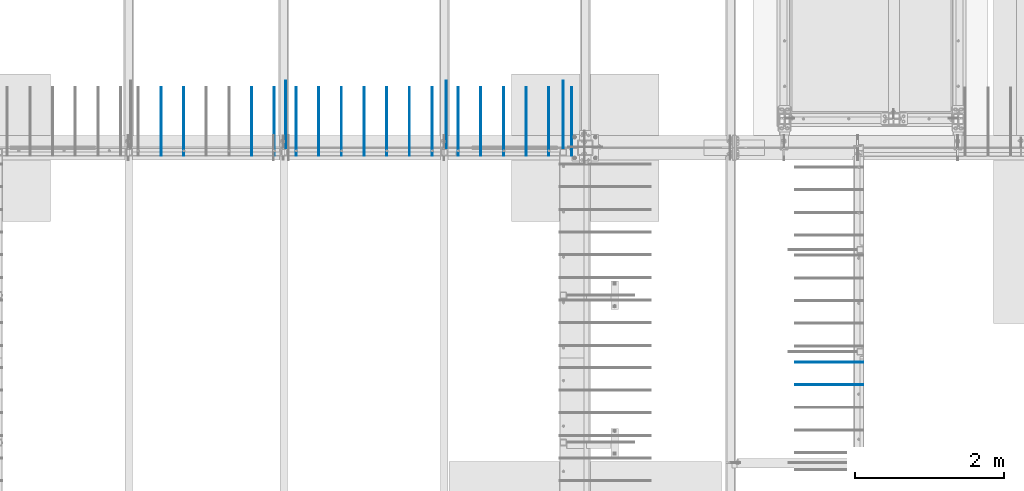
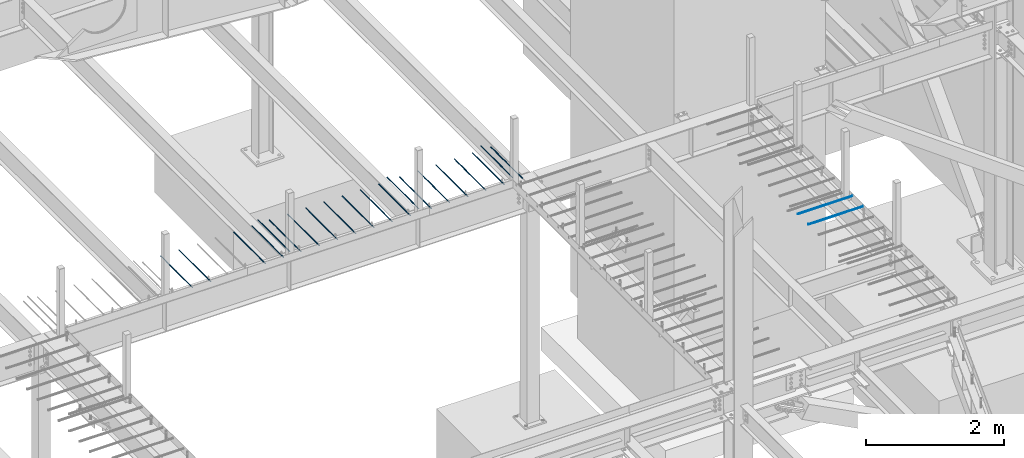
# One storey, part 821 of 1179: 22 beams, 22 elements without a shape of their own.
"""IFC2X3 building model written with IfcOpenShell, lengths in millimetres."""

from ifc_helpers import new_model, si_unit, frame, origin_with_axes, place, context, subcontext, project, spatial, faceted_brep, material, type_object, element, aggregate, save


model = new_model("IFC2X3")

# Units and contexts
model_context = context("Model", 3, precision=1e-05, world=origin_with_axes())
body_context = subcontext(model_context, "Body", "Model", "MODEL_VIEW")
ifc_project = project(units=[si_unit("LENGTHUNIT", "METRE", prefix="MILLI"), si_unit("AREAUNIT", "SQUARE_METRE"), si_unit("VOLUMEUNIT", "CUBIC_METRE"), si_unit("MASSUNIT", "GRAM", prefix="KILO"), si_unit("TIMEUNIT", "SECOND"), si_unit("PLANEANGLEUNIT", "RADIAN"), si_unit("SOLIDANGLEUNIT", "STERADIAN"), si_unit("THERMODYNAMICTEMPERATUREUNIT", "DEGREE_CELSIUS"), si_unit("LUMINOUSINTENSITYUNIT", "LUMEN")], contexts=[model_context])

# Site, building, storey
site_placement = place(None, origin_with_axes())
site = spatial("IfcSite", under=ifc_project, at=site_placement, CompositionType="ELEMENT")
building_placement = place(site_placement, origin_with_axes())
building = spatial("IfcBuilding", under=site, at=building_placement, Name="Undefined", CompositionType="ELEMENT")
storey_placement = place(building_placement, origin_with_axes())
storey = spatial("IfcBuildingStorey", under=building, at=storey_placement, Name="Undefined", CompositionType="ELEMENT", Elevation=0.0)

# Assembly, beam
assembly_1_placement = place(storey_placement, origin_with_axes())
assembly_1 = element("IfcElementAssembly", 1, at=assembly_1_placement, inside=storey, Name="#4 DOWEL", AssemblyPlace="NOTDEFINED", PredefinedType="NOTDEFINED")
ifc_material = material(Name="REBAR/A615-40")
beam_type = type_object("IfcBeamType", Name="#4 DOWEL", PredefinedType="NOTDEFINED")
beam_1_placement = place(assembly_1_placement, frame((14592.3, 11464.925, 4203.70000610352), z_axis=(0.0, 0.0, 1.0), x_axis=(0.0, 1.0, 0.0)))
beam_1 = element("IfcBeam", 2, at=beam_1_placement, type_object=beam_type, material=ifc_material, Name="#4 DOWEL", ObjectType="#4 DOWEL", context=body_context, shape_type="Brep", body=[
    faceted_brep([(0.0, -6.34999999999854, 0.0), (0.0, -4.49012806053361, -4.49012806053452), (914.399999999994, -4.49012806053452, -4.49012806042992), (914.399999999994, -6.34999999999991, 1.0550138540566e-10), (0.0, 0.0, -6.34999999999991), (914.399999999994, 0.0, -6.34999999989668), (0.0, 4.49012806053361, -4.49012806053452), (914.399999999994, 4.49012806053452, -4.49012806042992), (0.0, 6.34999999999854, 0.0), (914.399999999994, 6.34999999999991, 1.0550138540566e-10), (0.0, 4.49012806053361, 4.49012806053452), (914.399999999995, 4.49012806053452, 4.49012806064184), (0.0, 0.0, 6.34999999999991), (914.399999999995, 0.0, 6.35000000010768), (0.0, -4.49012806053361, 4.49012806053452), (914.399999999995, -4.49012806053452, 4.49012806064184)], [[[0, 1, 2, 3]], [[1, 4, 5, 2]], [[4, 6, 7, 5]], [[6, 8, 9, 7]], [[8, 10, 11, 9]], [[10, 12, 13, 11]], [[12, 14, 15, 13]], [[14, 0, 3, 15]], [[5, 7, 9, 11, 13, 15, 3, 2]], [[14, 12, 10, 8, 6, 4, 1, 0]]]),
])
aggregate(assembly_1, [beam_1])

assembly_2_placement = place(storey_placement, origin_with_axes())
assembly_2 = element("IfcElementAssembly", 3, at=assembly_2_placement, inside=storey, Name="#4 DOWEL", AssemblyPlace="NOTDEFINED", PredefinedType="NOTDEFINED")
beam_2_placement = place(assembly_2_placement, frame((12433.3, 11464.925, 4203.70000610352), z_axis=(0.0, 0.0, 1.0), x_axis=(0.0, 1.0, 0.0)))
beam_2 = element("IfcBeam", 4, at=beam_2_placement, type_object=beam_type, material=ifc_material, Name="#4 DOWEL", ObjectType="#4 DOWEL", context=body_context, shape_type="Brep", body=[
    faceted_brep([(0.0, -6.34999999999854, 0.0), (0.0, -4.49012806053361, -4.49012806053452), (914.399999999994, -4.49012806053452, -4.49012806042992), (914.399999999994, -6.34999999999991, 1.0550138540566e-10), (0.0, 0.0, -6.34999999999991), (914.399999999994, 0.0, -6.34999999989668), (0.0, 4.49012806053361, -4.49012806053452), (914.399999999994, 4.49012806053452, -4.49012806042992), (0.0, 6.34999999999854, 0.0), (914.399999999994, 6.34999999999991, 1.0550138540566e-10), (0.0, 4.49012806053361, 4.49012806053452), (914.399999999995, 4.49012806053452, 4.49012806064184), (0.0, 0.0, 6.34999999999991), (914.399999999995, 0.0, 6.35000000010768), (0.0, -4.49012806053361, 4.49012806053452), (914.399999999995, -4.49012806053452, 4.49012806064184)], [[[0, 1, 2, 3]], [[1, 4, 5, 2]], [[4, 6, 7, 5]], [[6, 8, 9, 7]], [[8, 10, 11, 9]], [[10, 12, 13, 11]], [[12, 14, 15, 13]], [[14, 0, 3, 15]], [[5, 7, 9, 11, 13, 15, 3, 2]], [[14, 12, 10, 8, 6, 4, 1, 0]]]),
])
aggregate(assembly_2, [beam_2])

assembly_3_placement = place(storey_placement, origin_with_axes())
assembly_3 = element("IfcElementAssembly", 5, at=assembly_3_placement, inside=storey, Name="#4 DOWEL", AssemblyPlace="NOTDEFINED", PredefinedType="NOTDEFINED")
beam_3_placement = place(assembly_3_placement, frame((19284.95, 8597.9, 4203.70000610352), z_axis=(0.0, 0.0, 1.0), x_axis=(1.0, 0.0, 0.0)))
beam_3 = element("IfcBeam", 6, at=beam_3_placement, type_object=beam_type, material=ifc_material, Name="#4 DOWEL", ObjectType="#4 DOWEL", context=body_context, shape_type="Brep", body=[
    faceted_brep([(0.0, -6.34999999999854, 0.0), (0.0, -4.49012806053361, -4.49012806053452), (914.399999999994, -4.49012806053452, -4.49012806042992), (914.399999999994, -6.34999999999991, 1.0550138540566e-10), (0.0, 0.0, -6.34999999999991), (914.399999999994, 0.0, -6.34999999989668), (0.0, 4.49012806053361, -4.49012806053452), (914.399999999994, 4.49012806053452, -4.49012806042992), (0.0, 6.34999999999854, 0.0), (914.399999999994, 6.34999999999991, 1.0550138540566e-10), (0.0, 4.49012806053361, 4.49012806053452), (914.399999999995, 4.49012806053452, 4.49012806064184), (0.0, 0.0, 6.34999999999991), (914.399999999995, 0.0, 6.35000000010768), (0.0, -4.49012806053361, 4.49012806053452), (914.399999999995, -4.49012806053452, 4.49012806064184)], [[[0, 1, 2, 3]], [[1, 4, 5, 2]], [[4, 6, 7, 5]], [[6, 8, 9, 7]], [[8, 10, 11, 9]], [[10, 12, 13, 11]], [[12, 14, 15, 13]], [[14, 0, 3, 15]], [[5, 7, 9, 11, 13, 15, 3, 2]], [[14, 12, 10, 8, 6, 4, 1, 0]]]),
])
aggregate(assembly_3, [beam_3])

assembly_4_placement = place(storey_placement, origin_with_axes())
assembly_4 = element("IfcElementAssembly", 7, at=assembly_4_placement, inside=storey, Name="#4 DOWEL", AssemblyPlace="NOTDEFINED", PredefinedType="NOTDEFINED")
beam_4_placement = place(assembly_4_placement, frame((19284.95, 8293.1, 4203.70000610352), z_axis=(0.0, 0.0, 1.0), x_axis=(1.0, 0.0, 0.0)))
beam_4 = element("IfcBeam", 8, at=beam_4_placement, type_object=beam_type, material=ifc_material, Name="#4 DOWEL", ObjectType="#4 DOWEL", context=body_context, shape_type="Brep", body=[
    faceted_brep([(0.0, -6.34999999999854, 0.0), (0.0, -4.49012806053361, -4.49012806053452), (914.399999999994, -4.49012806053452, -4.49012806042992), (914.399999999994, -6.34999999999991, 1.0550138540566e-10), (0.0, 0.0, -6.34999999999991), (914.399999999994, 0.0, -6.34999999989668), (0.0, 4.49012806053361, -4.49012806053452), (914.399999999994, 4.49012806053452, -4.49012806042992), (0.0, 6.34999999999854, 0.0), (914.399999999994, 6.34999999999991, 1.0550138540566e-10), (0.0, 4.49012806053361, 4.49012806053452), (914.399999999995, 4.49012806053452, 4.49012806064184), (0.0, 0.0, 6.34999999999991), (914.399999999995, 0.0, 6.35000000010768), (0.0, -4.49012806053361, 4.49012806053452), (914.399999999995, -4.49012806053452, 4.49012806064184)], [[[0, 1, 2, 3]], [[1, 4, 5, 2]], [[4, 6, 7, 5]], [[6, 8, 9, 7]], [[8, 10, 11, 9]], [[10, 12, 13, 11]], [[12, 14, 15, 13]], [[14, 0, 3, 15]], [[5, 7, 9, 11, 13, 15, 3, 2]], [[14, 12, 10, 8, 6, 4, 1, 0]]]),
])
aggregate(assembly_4, [beam_4])

assembly_5_placement = place(storey_placement, origin_with_axes())
assembly_5 = element("IfcElementAssembly", 9, at=assembly_5_placement, inside=storey, Name="#4 DOWEL", AssemblyPlace="NOTDEFINED", PredefinedType="NOTDEFINED")
beam_5_placement = place(assembly_5_placement, frame((16163.925, 11464.925, 4203.70000610352), z_axis=(0.0, 0.0, 1.0), x_axis=(0.0, 1.0, 0.0)))
beam_5 = element("IfcBeam", 10, at=beam_5_placement, type_object=beam_type, material=ifc_material, Name="#4 DOWEL", ObjectType="#4 DOWEL", context=body_context, shape_type="Brep", body=[
    faceted_brep([(0.0, -6.34999999999854, 0.0), (0.0, -4.49012806053361, -4.49012806053452), (914.399999999994, -4.49012806053452, -4.49012806042992), (914.399999999994, -6.34999999999991, 1.0550138540566e-10), (0.0, 0.0, -6.34999999999991), (914.399999999994, 0.0, -6.34999999989668), (0.0, 4.49012806053361, -4.49012806053452), (914.399999999994, 4.49012806053452, -4.49012806042992), (0.0, 6.34999999999854, 0.0), (914.399999999994, 6.34999999999991, 1.0550138540566e-10), (0.0, 4.49012806053361, 4.49012806053452), (914.399999999995, 4.49012806053452, 4.49012806064184), (0.0, 0.0, 6.34999999999991), (914.399999999995, 0.0, 6.35000000010768), (0.0, -4.49012806053361, 4.49012806053452), (914.399999999995, -4.49012806053452, 4.49012806064184)], [[[0, 1, 2, 3]], [[1, 4, 5, 2]], [[4, 6, 7, 5]], [[6, 8, 9, 7]], [[8, 10, 11, 9]], [[10, 12, 13, 11]], [[12, 14, 15, 13]], [[14, 0, 3, 15]], [[5, 7, 9, 11, 13, 15, 3, 2]], [[14, 12, 10, 8, 6, 4, 1, 0]]]),
])
aggregate(assembly_5, [beam_5])

assembly_6_placement = place(storey_placement, origin_with_axes())
assembly_6 = element("IfcElementAssembly", 11, at=assembly_6_placement, inside=storey, Name="#4 DOWEL", AssemblyPlace="NOTDEFINED", PredefinedType="NOTDEFINED")
beam_6_placement = place(assembly_6_placement, frame((16276.6375, 11376.025, 4203.70000610352), z_axis=(0.0, 0.0, 1.0), x_axis=(0.0, 1.0, 0.0)))
beam_6 = element("IfcBeam", 12, at=beam_6_placement, type_object=beam_type, material=ifc_material, Name="#4 DOWEL", ObjectType="#4 DOWEL", context=body_context, shape_type="Brep", body=[
    faceted_brep([(0.0, -6.34999999999854, 0.0), (0.0, -4.49012806053361, -4.49012806053452), (914.399999999994, -4.49012806053452, -4.49012806042992), (914.399999999994, -6.34999999999991, 1.0550138540566e-10), (0.0, 0.0, -6.34999999999991), (914.399999999994, 0.0, -6.34999999989668), (0.0, 4.49012806053361, -4.49012806053452), (914.399999999994, 4.49012806053452, -4.49012806042992), (0.0, 6.34999999999854, 0.0), (914.399999999994, 6.34999999999991, 1.0550138540566e-10), (0.0, 4.49012806053361, 4.49012806053452), (914.399999999995, 4.49012806053452, 4.49012806064184), (0.0, 0.0, 6.34999999999991), (914.399999999995, 0.0, 6.35000000010768), (0.0, -4.49012806053361, 4.49012806053452), (914.399999999995, -4.49012806053452, 4.49012806064184)], [[[0, 1, 2, 3]], [[1, 4, 5, 2]], [[4, 6, 7, 5]], [[6, 8, 9, 7]], [[8, 10, 11, 9]], [[10, 12, 13, 11]], [[12, 14, 15, 13]], [[14, 0, 3, 15]], [[5, 7, 9, 11, 13, 15, 3, 2]], [[14, 12, 10, 8, 6, 4, 1, 0]]]),
])
aggregate(assembly_6, [beam_6])

assembly_7_placement = place(storey_placement, origin_with_axes())
assembly_7 = element("IfcElementAssembly", 13, at=assembly_7_placement, inside=storey, Name="#4 DOWEL", AssemblyPlace="NOTDEFINED", PredefinedType="NOTDEFINED")
beam_7_placement = place(assembly_7_placement, frame((15971.8375, 11376.025, 4203.70000610352), z_axis=(0.0, 0.0, 1.0), x_axis=(0.0, 1.0, 0.0)))
beam_7 = element("IfcBeam", 14, at=beam_7_placement, type_object=beam_type, material=ifc_material, Name="#4 DOWEL", ObjectType="#4 DOWEL", context=body_context, shape_type="Brep", body=[
    faceted_brep([(0.0, -6.34999999999854, 0.0), (0.0, -4.49012806053361, -4.49012806053452), (914.399999999994, -4.49012806053452, -4.49012806042992), (914.399999999994, -6.34999999999991, 1.0550138540566e-10), (0.0, 0.0, -6.34999999999991), (914.399999999994, 0.0, -6.34999999989668), (0.0, 4.49012806053361, -4.49012806053452), (914.399999999994, 4.49012806053452, -4.49012806042992), (0.0, 6.34999999999854, 0.0), (914.399999999994, 6.34999999999991, 1.0550138540566e-10), (0.0, 4.49012806053361, 4.49012806053452), (914.399999999995, 4.49012806053452, 4.49012806064184), (0.0, 0.0, 6.34999999999991), (914.399999999995, 0.0, 6.35000000010768), (0.0, -4.49012806053361, 4.49012806053452), (914.399999999995, -4.49012806053452, 4.49012806064184)], [[[0, 1, 2, 3]], [[1, 4, 5, 2]], [[4, 6, 7, 5]], [[6, 8, 9, 7]], [[8, 10, 11, 9]], [[10, 12, 13, 11]], [[12, 14, 15, 13]], [[14, 0, 3, 15]], [[5, 7, 9, 11, 13, 15, 3, 2]], [[14, 12, 10, 8, 6, 4, 1, 0]]]),
])
aggregate(assembly_7, [beam_7])

assembly_8_placement = place(storey_placement, origin_with_axes())
assembly_8 = element("IfcElementAssembly", 15, at=assembly_8_placement, inside=storey, Name="#4 DOWEL", AssemblyPlace="NOTDEFINED", PredefinedType="NOTDEFINED")
beam_8_placement = place(assembly_8_placement, frame((15667.0375, 11376.025, 4203.70000610352), z_axis=(0.0, 0.0, 1.0), x_axis=(0.0, 1.0, 0.0)))
beam_8 = element("IfcBeam", 16, at=beam_8_placement, type_object=beam_type, material=ifc_material, Name="#4 DOWEL", ObjectType="#4 DOWEL", context=body_context, shape_type="Brep", body=[
    faceted_brep([(0.0, -6.34999999999854, 0.0), (0.0, -4.49012806053361, -4.49012806053452), (914.399999999994, -4.49012806053452, -4.49012806042992), (914.399999999994, -6.34999999999991, 1.0550138540566e-10), (0.0, 0.0, -6.34999999999991), (914.399999999994, 0.0, -6.34999999989668), (0.0, 4.49012806053361, -4.49012806053452), (914.399999999994, 4.49012806053452, -4.49012806042992), (0.0, 6.34999999999854, 0.0), (914.399999999994, 6.34999999999991, 1.0550138540566e-10), (0.0, 4.49012806053361, 4.49012806053452), (914.399999999995, 4.49012806053452, 4.49012806064184), (0.0, 0.0, 6.34999999999991), (914.399999999995, 0.0, 6.35000000010768), (0.0, -4.49012806053361, 4.49012806053452), (914.399999999995, -4.49012806053452, 4.49012806064184)], [[[0, 1, 2, 3]], [[1, 4, 5, 2]], [[4, 6, 7, 5]], [[6, 8, 9, 7]], [[8, 10, 11, 9]], [[10, 12, 13, 11]], [[12, 14, 15, 13]], [[14, 0, 3, 15]], [[5, 7, 9, 11, 13, 15, 3, 2]], [[14, 12, 10, 8, 6, 4, 1, 0]]]),
])
aggregate(assembly_8, [beam_8])

assembly_9_placement = place(storey_placement, origin_with_axes())
assembly_9 = element("IfcElementAssembly", 17, at=assembly_9_placement, inside=storey, Name="#4 DOWEL", AssemblyPlace="NOTDEFINED", PredefinedType="NOTDEFINED")
beam_9_placement = place(assembly_9_placement, frame((15362.2375, 11376.025, 4203.70000610352), z_axis=(0.0, 0.0, 1.0), x_axis=(0.0, 1.0, 0.0)))
beam_9 = element("IfcBeam", 18, at=beam_9_placement, type_object=beam_type, material=ifc_material, Name="#4 DOWEL", ObjectType="#4 DOWEL", context=body_context, shape_type="Brep", body=[
    faceted_brep([(0.0, -6.34999999999854, 0.0), (0.0, -4.49012806053361, -4.49012806053452), (914.399999999994, -4.49012806053452, -4.49012806042992), (914.399999999994, -6.34999999999991, 1.0550138540566e-10), (0.0, 0.0, -6.34999999999991), (914.399999999994, 0.0, -6.34999999989668), (0.0, 4.49012806053361, -4.49012806053452), (914.399999999994, 4.49012806053452, -4.49012806042992), (0.0, 6.34999999999854, 0.0), (914.399999999994, 6.34999999999991, 1.0550138540566e-10), (0.0, 4.49012806053361, 4.49012806053452), (914.399999999995, 4.49012806053452, 4.49012806064184), (0.0, 0.0, 6.34999999999991), (914.399999999995, 0.0, 6.35000000010768), (0.0, -4.49012806053361, 4.49012806053452), (914.399999999995, -4.49012806053452, 4.49012806064184)], [[[0, 1, 2, 3]], [[1, 4, 5, 2]], [[4, 6, 7, 5]], [[6, 8, 9, 7]], [[8, 10, 11, 9]], [[10, 12, 13, 11]], [[12, 14, 15, 13]], [[14, 0, 3, 15]], [[5, 7, 9, 11, 13, 15, 3, 2]], [[14, 12, 10, 8, 6, 4, 1, 0]]]),
])
aggregate(assembly_9, [beam_9])

assembly_10_placement = place(storey_placement, origin_with_axes())
assembly_10 = element("IfcElementAssembly", 19, at=assembly_10_placement, inside=storey, Name="#4 DOWEL", AssemblyPlace="NOTDEFINED", PredefinedType="NOTDEFINED")
beam_10_placement = place(assembly_10_placement, frame((15057.4375, 11376.025, 4203.70000610352), z_axis=(0.0, 0.0, 1.0), x_axis=(0.0, 1.0, 0.0)))
beam_10 = element("IfcBeam", 20, at=beam_10_placement, type_object=beam_type, material=ifc_material, Name="#4 DOWEL", ObjectType="#4 DOWEL", context=body_context, shape_type="Brep", body=[
    faceted_brep([(0.0, -6.34999999999854, 0.0), (0.0, -4.49012806053361, -4.49012806053452), (914.399999999994, -4.49012806053452, -4.49012806042992), (914.399999999994, -6.34999999999991, 1.0550138540566e-10), (0.0, 0.0, -6.34999999999991), (914.399999999994, 0.0, -6.34999999989668), (0.0, 4.49012806053361, -4.49012806053452), (914.399999999994, 4.49012806053452, -4.49012806042992), (0.0, 6.34999999999854, 0.0), (914.399999999994, 6.34999999999991, 1.0550138540566e-10), (0.0, 4.49012806053361, 4.49012806053452), (914.399999999995, 4.49012806053452, 4.49012806064184), (0.0, 0.0, 6.34999999999991), (914.399999999995, 0.0, 6.35000000010768), (0.0, -4.49012806053361, 4.49012806053452), (914.399999999995, -4.49012806053452, 4.49012806064184)], [[[0, 1, 2, 3]], [[1, 4, 5, 2]], [[4, 6, 7, 5]], [[6, 8, 9, 7]], [[8, 10, 11, 9]], [[10, 12, 13, 11]], [[12, 14, 15, 13]], [[14, 0, 3, 15]], [[5, 7, 9, 11, 13, 15, 3, 2]], [[14, 12, 10, 8, 6, 4, 1, 0]]]),
])
aggregate(assembly_10, [beam_10])

assembly_11_placement = place(storey_placement, origin_with_axes())
assembly_11 = element("IfcElementAssembly", 21, at=assembly_11_placement, inside=storey, Name="#4 DOWEL", AssemblyPlace="NOTDEFINED", PredefinedType="NOTDEFINED")
beam_11_placement = place(assembly_11_placement, frame((14752.6375, 11376.025, 4203.70000610352), z_axis=(0.0, 0.0, 1.0), x_axis=(0.0, 1.0, 0.0)))
beam_11 = element("IfcBeam", 22, at=beam_11_placement, type_object=beam_type, material=ifc_material, Name="#4 DOWEL", ObjectType="#4 DOWEL", context=body_context, shape_type="Brep", body=[
    faceted_brep([(0.0, -6.34999999999854, 0.0), (0.0, -4.49012806053361, -4.49012806053452), (914.399999999994, -4.49012806053452, -4.49012806042992), (914.399999999994, -6.34999999999991, 1.0550138540566e-10), (0.0, 0.0, -6.34999999999991), (914.399999999994, 0.0, -6.34999999989668), (0.0, 4.49012806053361, -4.49012806053452), (914.399999999994, 4.49012806053452, -4.49012806042992), (0.0, 6.34999999999854, 0.0), (914.399999999994, 6.34999999999991, 1.0550138540566e-10), (0.0, 4.49012806053361, 4.49012806053452), (914.399999999995, 4.49012806053452, 4.49012806064184), (0.0, 0.0, 6.34999999999991), (914.399999999995, 0.0, 6.35000000010768), (0.0, -4.49012806053361, 4.49012806053452), (914.399999999995, -4.49012806053452, 4.49012806064184)], [[[0, 1, 2, 3]], [[1, 4, 5, 2]], [[4, 6, 7, 5]], [[6, 8, 9, 7]], [[8, 10, 11, 9]], [[10, 12, 13, 11]], [[12, 14, 15, 13]], [[14, 0, 3, 15]], [[5, 7, 9, 11, 13, 15, 3, 2]], [[14, 12, 10, 8, 6, 4, 1, 0]]]),
])
aggregate(assembly_11, [beam_11])

assembly_12_placement = place(storey_placement, origin_with_axes())
assembly_12 = element("IfcElementAssembly", 23, at=assembly_12_placement, inside=storey, Name="#4 DOWEL", AssemblyPlace="NOTDEFINED", PredefinedType="NOTDEFINED")
beam_12_placement = place(assembly_12_placement, frame((14401.8, 11376.025, 4203.70000610352), z_axis=(0.0, 0.0, 1.0), x_axis=(0.0, 1.0, 0.0)))
beam_12 = element("IfcBeam", 24, at=beam_12_placement, type_object=beam_type, material=ifc_material, Name="#4 DOWEL", ObjectType="#4 DOWEL", context=body_context, shape_type="Brep", body=[
    faceted_brep([(0.0, -6.34999999999854, 0.0), (0.0, -4.49012806053361, -4.49012806053452), (914.399999999994, -4.49012806053452, -4.49012806042992), (914.399999999994, -6.34999999999991, 1.0550138540566e-10), (0.0, 0.0, -6.34999999999991), (914.399999999994, 0.0, -6.34999999989668), (0.0, 4.49012806053361, -4.49012806053452), (914.399999999994, 4.49012806053452, -4.49012806042992), (0.0, 6.34999999999854, 0.0), (914.399999999994, 6.34999999999991, 1.0550138540566e-10), (0.0, 4.49012806053361, 4.49012806053452), (914.399999999995, 4.49012806053452, 4.49012806064184), (0.0, 0.0, 6.34999999999991), (914.399999999995, 0.0, 6.35000000010768), (0.0, -4.49012806053361, 4.49012806053452), (914.399999999995, -4.49012806053452, 4.49012806064184)], [[[0, 1, 2, 3]], [[1, 4, 5, 2]], [[4, 6, 7, 5]], [[6, 8, 9, 7]], [[8, 10, 11, 9]], [[10, 12, 13, 11]], [[12, 14, 15, 13]], [[14, 0, 3, 15]], [[5, 7, 9, 11, 13, 15, 3, 2]], [[14, 12, 10, 8, 6, 4, 1, 0]]]),
])
aggregate(assembly_12, [beam_12])

assembly_13_placement = place(storey_placement, origin_with_axes())
assembly_13 = element("IfcElementAssembly", 25, at=assembly_13_placement, inside=storey, Name="#4 DOWEL", AssemblyPlace="NOTDEFINED", PredefinedType="NOTDEFINED")
beam_13_placement = place(assembly_13_placement, frame((14097.0, 11376.025, 4203.70000610352), z_axis=(0.0, 0.0, 1.0), x_axis=(0.0, 1.0, 0.0)))
beam_13 = element("IfcBeam", 26, at=beam_13_placement, type_object=beam_type, material=ifc_material, Name="#4 DOWEL", ObjectType="#4 DOWEL", context=body_context, shape_type="Brep", body=[
    faceted_brep([(0.0, -6.34999999999854, 0.0), (0.0, -4.49012806053361, -4.49012806053452), (914.399999999994, -4.49012806053452, -4.49012806042992), (914.399999999994, -6.34999999999991, 1.0550138540566e-10), (0.0, 0.0, -6.34999999999991), (914.399999999994, 0.0, -6.34999999989668), (0.0, 4.49012806053361, -4.49012806053452), (914.399999999994, 4.49012806053452, -4.49012806042992), (0.0, 6.34999999999854, 0.0), (914.399999999994, 6.34999999999991, 1.0550138540566e-10), (0.0, 4.49012806053361, 4.49012806053452), (914.399999999995, 4.49012806053452, 4.49012806064184), (0.0, 0.0, 6.34999999999991), (914.399999999995, 0.0, 6.35000000010768), (0.0, -4.49012806053361, 4.49012806053452), (914.399999999995, -4.49012806053452, 4.49012806064184)], [[[0, 1, 2, 3]], [[1, 4, 5, 2]], [[4, 6, 7, 5]], [[6, 8, 9, 7]], [[8, 10, 11, 9]], [[10, 12, 13, 11]], [[12, 14, 15, 13]], [[14, 0, 3, 15]], [[5, 7, 9, 11, 13, 15, 3, 2]], [[14, 12, 10, 8, 6, 4, 1, 0]]]),
])
aggregate(assembly_13, [beam_13])

assembly_14_placement = place(storey_placement, origin_with_axes())
assembly_14 = element("IfcElementAssembly", 27, at=assembly_14_placement, inside=storey, Name="#4 DOWEL", AssemblyPlace="NOTDEFINED", PredefinedType="NOTDEFINED")
beam_14_placement = place(assembly_14_placement, frame((13792.2, 11376.025, 4203.70000610352), z_axis=(0.0, 0.0, 1.0), x_axis=(0.0, 1.0, 0.0)))
beam_14 = element("IfcBeam", 28, at=beam_14_placement, type_object=beam_type, material=ifc_material, Name="#4 DOWEL", ObjectType="#4 DOWEL", context=body_context, shape_type="Brep", body=[
    faceted_brep([(0.0, -6.34999999999854, 0.0), (0.0, -4.49012806053361, -4.49012806053452), (914.399999999994, -4.49012806053452, -4.49012806042992), (914.399999999994, -6.34999999999991, 1.0550138540566e-10), (0.0, 0.0, -6.34999999999991), (914.399999999994, 0.0, -6.34999999989668), (0.0, 4.49012806053361, -4.49012806053452), (914.399999999994, 4.49012806053452, -4.49012806042992), (0.0, 6.34999999999854, 0.0), (914.399999999994, 6.34999999999991, 1.0550138540566e-10), (0.0, 4.49012806053361, 4.49012806053452), (914.399999999995, 4.49012806053452, 4.49012806064184), (0.0, 0.0, 6.34999999999991), (914.399999999995, 0.0, 6.35000000010768), (0.0, -4.49012806053361, 4.49012806053452), (914.399999999995, -4.49012806053452, 4.49012806064184)], [[[0, 1, 2, 3]], [[1, 4, 5, 2]], [[4, 6, 7, 5]], [[6, 8, 9, 7]], [[8, 10, 11, 9]], [[10, 12, 13, 11]], [[12, 14, 15, 13]], [[14, 0, 3, 15]], [[5, 7, 9, 11, 13, 15, 3, 2]], [[14, 12, 10, 8, 6, 4, 1, 0]]]),
])
aggregate(assembly_14, [beam_14])

assembly_15_placement = place(storey_placement, origin_with_axes())
assembly_15 = element("IfcElementAssembly", 29, at=assembly_15_placement, inside=storey, Name="#4 DOWEL", AssemblyPlace="NOTDEFINED", PredefinedType="NOTDEFINED")
beam_15_placement = place(assembly_15_placement, frame((13487.4, 11376.025, 4203.70000610352), z_axis=(0.0, 0.0, 1.0), x_axis=(0.0, 1.0, 0.0)))
beam_15 = element("IfcBeam", 30, at=beam_15_placement, type_object=beam_type, material=ifc_material, Name="#4 DOWEL", ObjectType="#4 DOWEL", context=body_context, shape_type="Brep", body=[
    faceted_brep([(0.0, -6.34999999999854, 0.0), (0.0, -4.49012806053361, -4.49012806053452), (914.399999999994, -4.49012806053452, -4.49012806042992), (914.399999999994, -6.34999999999991, 1.0550138540566e-10), (0.0, 0.0, -6.34999999999991), (914.399999999994, 0.0, -6.34999999989668), (0.0, 4.49012806053361, -4.49012806053452), (914.399999999994, 4.49012806053452, -4.49012806042992), (0.0, 6.34999999999854, 0.0), (914.399999999994, 6.34999999999991, 1.0550138540566e-10), (0.0, 4.49012806053361, 4.49012806053452), (914.399999999995, 4.49012806053452, 4.49012806064184), (0.0, 0.0, 6.34999999999991), (914.399999999995, 0.0, 6.35000000010768), (0.0, -4.49012806053361, 4.49012806053452), (914.399999999995, -4.49012806053452, 4.49012806064184)], [[[0, 1, 2, 3]], [[1, 4, 5, 2]], [[4, 6, 7, 5]], [[6, 8, 9, 7]], [[8, 10, 11, 9]], [[10, 12, 13, 11]], [[12, 14, 15, 13]], [[14, 0, 3, 15]], [[5, 7, 9, 11, 13, 15, 3, 2]], [[14, 12, 10, 8, 6, 4, 1, 0]]]),
])
aggregate(assembly_15, [beam_15])

assembly_16_placement = place(storey_placement, origin_with_axes())
assembly_16 = element("IfcElementAssembly", 31, at=assembly_16_placement, inside=storey, Name="#4 DOWEL", AssemblyPlace="NOTDEFINED", PredefinedType="NOTDEFINED")
beam_16_placement = place(assembly_16_placement, frame((13182.6, 11376.025, 4203.70000610352), z_axis=(0.0, 0.0, 1.0), x_axis=(0.0, 1.0, 0.0)))
beam_16 = element("IfcBeam", 32, at=beam_16_placement, type_object=beam_type, material=ifc_material, Name="#4 DOWEL", ObjectType="#4 DOWEL", context=body_context, shape_type="Brep", body=[
    faceted_brep([(0.0, -6.34999999999854, 0.0), (0.0, -4.49012806053361, -4.49012806053452), (914.399999999994, -4.49012806053452, -4.49012806042992), (914.399999999994, -6.34999999999991, 1.0550138540566e-10), (0.0, 0.0, -6.34999999999991), (914.399999999994, 0.0, -6.34999999989668), (0.0, 4.49012806053361, -4.49012806053452), (914.399999999994, 4.49012806053452, -4.49012806042992), (0.0, 6.34999999999854, 0.0), (914.399999999994, 6.34999999999991, 1.0550138540566e-10), (0.0, 4.49012806053361, 4.49012806053452), (914.399999999995, 4.49012806053452, 4.49012806064184), (0.0, 0.0, 6.34999999999991), (914.399999999995, 0.0, 6.35000000010768), (0.0, -4.49012806053361, 4.49012806053452), (914.399999999995, -4.49012806053452, 4.49012806064184)], [[[0, 1, 2, 3]], [[1, 4, 5, 2]], [[4, 6, 7, 5]], [[6, 8, 9, 7]], [[8, 10, 11, 9]], [[10, 12, 13, 11]], [[12, 14, 15, 13]], [[14, 0, 3, 15]], [[5, 7, 9, 11, 13, 15, 3, 2]], [[14, 12, 10, 8, 6, 4, 1, 0]]]),
])
aggregate(assembly_16, [beam_16])

assembly_17_placement = place(storey_placement, origin_with_axes())
assembly_17 = element("IfcElementAssembly", 33, at=assembly_17_placement, inside=storey, Name="#4 DOWEL", AssemblyPlace="NOTDEFINED", PredefinedType="NOTDEFINED")
beam_17_placement = place(assembly_17_placement, frame((12877.8, 11376.025, 4203.70000610352), z_axis=(0.0, 0.0, 1.0), x_axis=(0.0, 1.0, 0.0)))
beam_17 = element("IfcBeam", 34, at=beam_17_placement, type_object=beam_type, material=ifc_material, Name="#4 DOWEL", ObjectType="#4 DOWEL", context=body_context, shape_type="Brep", body=[
    faceted_brep([(0.0, -6.34999999999854, 0.0), (0.0, -4.49012806053361, -4.49012806053452), (914.399999999994, -4.49012806053452, -4.49012806042992), (914.399999999994, -6.34999999999991, 1.0550138540566e-10), (0.0, 0.0, -6.34999999999991), (914.399999999994, 0.0, -6.34999999989668), (0.0, 4.49012806053361, -4.49012806053452), (914.399999999994, 4.49012806053452, -4.49012806042992), (0.0, 6.34999999999854, 0.0), (914.399999999994, 6.34999999999991, 1.0550138540566e-10), (0.0, 4.49012806053361, 4.49012806053452), (914.399999999995, 4.49012806053452, 4.49012806064184), (0.0, 0.0, 6.34999999999991), (914.399999999995, 0.0, 6.35000000010768), (0.0, -4.49012806053361, 4.49012806053452), (914.399999999995, -4.49012806053452, 4.49012806064184)], [[[0, 1, 2, 3]], [[1, 4, 5, 2]], [[4, 6, 7, 5]], [[6, 8, 9, 7]], [[8, 10, 11, 9]], [[10, 12, 13, 11]], [[12, 14, 15, 13]], [[14, 0, 3, 15]], [[5, 7, 9, 11, 13, 15, 3, 2]], [[14, 12, 10, 8, 6, 4, 1, 0]]]),
])
aggregate(assembly_17, [beam_17])

assembly_18_placement = place(storey_placement, origin_with_axes())
assembly_18 = element("IfcElementAssembly", 35, at=assembly_18_placement, inside=storey, Name="#4 DOWEL", AssemblyPlace="NOTDEFINED", PredefinedType="NOTDEFINED")
beam_18_placement = place(assembly_18_placement, frame((12573.0, 11376.025, 4203.70000610352), z_axis=(0.0, 0.0, 1.0), x_axis=(0.0, 1.0, 0.0)))
beam_18 = element("IfcBeam", 36, at=beam_18_placement, type_object=beam_type, material=ifc_material, Name="#4 DOWEL", ObjectType="#4 DOWEL", context=body_context, shape_type="Brep", body=[
    faceted_brep([(0.0, -6.34999999999854, 0.0), (0.0, -4.49012806053361, -4.49012806053452), (914.399999999994, -4.49012806053452, -4.49012806042992), (914.399999999994, -6.34999999999991, 1.0550138540566e-10), (0.0, 0.0, -6.34999999999991), (914.399999999994, 0.0, -6.34999999989668), (0.0, 4.49012806053361, -4.49012806053452), (914.399999999994, 4.49012806053452, -4.49012806042992), (0.0, 6.34999999999854, 0.0), (914.399999999994, 6.34999999999991, 1.0550138540566e-10), (0.0, 4.49012806053361, 4.49012806053452), (914.399999999995, 4.49012806053452, 4.49012806064184), (0.0, 0.0, 6.34999999999991), (914.399999999995, 0.0, 6.35000000010768), (0.0, -4.49012806053361, 4.49012806053452), (914.399999999995, -4.49012806053452, 4.49012806064184)], [[[0, 1, 2, 3]], [[1, 4, 5, 2]], [[4, 6, 7, 5]], [[6, 8, 9, 7]], [[8, 10, 11, 9]], [[10, 12, 13, 11]], [[12, 14, 15, 13]], [[14, 0, 3, 15]], [[5, 7, 9, 11, 13, 15, 3, 2]], [[14, 12, 10, 8, 6, 4, 1, 0]]]),
])
aggregate(assembly_18, [beam_18])

assembly_19_placement = place(storey_placement, origin_with_axes())
assembly_19 = element("IfcElementAssembly", 37, at=assembly_19_placement, inside=storey, Name="#4 DOWEL", AssemblyPlace="NOTDEFINED", PredefinedType="NOTDEFINED")
beam_19_placement = place(assembly_19_placement, frame((12280.9, 11376.025, 4203.70000610352), z_axis=(0.0, 0.0, 1.0), x_axis=(0.0, 1.0, 0.0)))
beam_19 = element("IfcBeam", 38, at=beam_19_placement, type_object=beam_type, material=ifc_material, Name="#4 DOWEL", ObjectType="#4 DOWEL", context=body_context, shape_type="Brep", body=[
    faceted_brep([(0.0, -6.34999999999854, 0.0), (0.0, -4.49012806053361, -4.49012806053452), (914.399999999994, -4.49012806053452, -4.49012806042992), (914.399999999994, -6.34999999999991, 1.0550138540566e-10), (0.0, 0.0, -6.34999999999991), (914.399999999994, 0.0, -6.34999999989668), (0.0, 4.49012806053361, -4.49012806053452), (914.399999999994, 4.49012806053452, -4.49012806042992), (0.0, 6.34999999999854, 0.0), (914.399999999994, 6.34999999999991, 1.0550138540566e-10), (0.0, 4.49012806053361, 4.49012806053452), (914.399999999995, 4.49012806053452, 4.49012806064184), (0.0, 0.0, 6.34999999999991), (914.399999999995, 0.0, 6.35000000010768), (0.0, -4.49012806053361, 4.49012806053452), (914.399999999995, -4.49012806053452, 4.49012806064184)], [[[0, 1, 2, 3]], [[1, 4, 5, 2]], [[4, 6, 7, 5]], [[6, 8, 9, 7]], [[8, 10, 11, 9]], [[10, 12, 13, 11]], [[12, 14, 15, 13]], [[14, 0, 3, 15]], [[5, 7, 9, 11, 13, 15, 3, 2]], [[14, 12, 10, 8, 6, 4, 1, 0]]]),
])
aggregate(assembly_19, [beam_19])

assembly_20_placement = place(storey_placement, origin_with_axes())
assembly_20 = element("IfcElementAssembly", 39, at=assembly_20_placement, inside=storey, Name="#4 DOWEL", AssemblyPlace="NOTDEFINED", PredefinedType="NOTDEFINED")
beam_20_placement = place(assembly_20_placement, frame((11976.1, 11376.025, 4203.70000610352), z_axis=(0.0, 0.0, 1.0), x_axis=(0.0, 1.0, 0.0)))
beam_20 = element("IfcBeam", 40, at=beam_20_placement, type_object=beam_type, material=ifc_material, Name="#4 DOWEL", ObjectType="#4 DOWEL", context=body_context, shape_type="Brep", body=[
    faceted_brep([(0.0, -6.34999999999854, 0.0), (0.0, -4.49012806053361, -4.49012806053452), (914.399999999994, -4.49012806053452, -4.49012806042992), (914.399999999994, -6.34999999999991, 1.0550138540566e-10), (0.0, 0.0, -6.34999999999991), (914.399999999994, 0.0, -6.34999999989668), (0.0, 4.49012806053361, -4.49012806053452), (914.399999999994, 4.49012806053452, -4.49012806042992), (0.0, 6.34999999999854, 0.0), (914.399999999994, 6.34999999999991, 1.0550138540566e-10), (0.0, 4.49012806053361, 4.49012806053452), (914.399999999995, 4.49012806053452, 4.49012806064184), (0.0, 0.0, 6.34999999999991), (914.399999999995, 0.0, 6.35000000010768), (0.0, -4.49012806053361, 4.49012806053452), (914.399999999995, -4.49012806053452, 4.49012806064184)], [[[0, 1, 2, 3]], [[1, 4, 5, 2]], [[4, 6, 7, 5]], [[6, 8, 9, 7]], [[8, 10, 11, 9]], [[10, 12, 13, 11]], [[12, 14, 15, 13]], [[14, 0, 3, 15]], [[5, 7, 9, 11, 13, 15, 3, 2]], [[14, 12, 10, 8, 6, 4, 1, 0]]]),
])
aggregate(assembly_20, [beam_20])

assembly_21_placement = place(storey_placement, origin_with_axes())
assembly_21 = element("IfcElementAssembly", 41, at=assembly_21_placement, inside=storey, Name="#4 DOWEL", AssemblyPlace="NOTDEFINED", PredefinedType="NOTDEFINED")
beam_21_placement = place(assembly_21_placement, frame((11061.7, 11376.025, 4203.70000610352), z_axis=(0.0, 0.0, 1.0), x_axis=(0.0, 1.0, 0.0)))
beam_21 = element("IfcBeam", 42, at=beam_21_placement, type_object=beam_type, material=ifc_material, Name="#4 DOWEL", ObjectType="#4 DOWEL", context=body_context, shape_type="Brep", body=[
    faceted_brep([(0.0, -6.34999999999854, 0.0), (0.0, -4.49012806053361, -4.49012806053452), (914.399999999994, -4.49012806053452, -4.49012806042992), (914.399999999994, -6.34999999999991, 1.0550138540566e-10), (0.0, 0.0, -6.34999999999991), (914.399999999994, 0.0, -6.34999999989668), (0.0, 4.49012806053361, -4.49012806053452), (914.399999999994, 4.49012806053452, -4.49012806042992), (0.0, 6.34999999999854, 0.0), (914.399999999994, 6.34999999999991, 1.0550138540566e-10), (0.0, 4.49012806053361, 4.49012806053452), (914.399999999995, 4.49012806053452, 4.49012806064184), (0.0, 0.0, 6.34999999999991), (914.399999999995, 0.0, 6.35000000010768), (0.0, -4.49012806053361, 4.49012806053452), (914.399999999995, -4.49012806053452, 4.49012806064184)], [[[0, 1, 2, 3]], [[1, 4, 5, 2]], [[4, 6, 7, 5]], [[6, 8, 9, 7]], [[8, 10, 11, 9]], [[10, 12, 13, 11]], [[12, 14, 15, 13]], [[14, 0, 3, 15]], [[5, 7, 9, 11, 13, 15, 3, 2]], [[14, 12, 10, 8, 6, 4, 1, 0]]]),
])
aggregate(assembly_21, [beam_21])

assembly_22_placement = place(storey_placement, origin_with_axes())
assembly_22 = element("IfcElementAssembly", 43, at=assembly_22_placement, inside=storey, Name="#4 DOWEL", AssemblyPlace="NOTDEFINED", PredefinedType="NOTDEFINED")
beam_22_placement = place(assembly_22_placement, frame((10756.9, 11376.025, 4203.70000610352), z_axis=(0.0, 0.0, 1.0), x_axis=(0.0, 1.0, 0.0)))
beam_22 = element("IfcBeam", 44, at=beam_22_placement, type_object=beam_type, material=ifc_material, Name="#4 DOWEL", ObjectType="#4 DOWEL", context=body_context, shape_type="Brep", body=[
    faceted_brep([(0.0, -6.34999999999854, 0.0), (0.0, -4.49012806053361, -4.49012806053452), (914.399999999994, -4.49012806053452, -4.49012806042992), (914.399999999994, -6.34999999999991, 1.0550138540566e-10), (0.0, 0.0, -6.34999999999991), (914.399999999994, 0.0, -6.34999999989668), (0.0, 4.49012806053361, -4.49012806053452), (914.399999999994, 4.49012806053452, -4.49012806042992), (0.0, 6.34999999999854, 0.0), (914.399999999994, 6.34999999999991, 1.0550138540566e-10), (0.0, 4.49012806053361, 4.49012806053452), (914.399999999995, 4.49012806053452, 4.49012806064184), (0.0, 0.0, 6.34999999999991), (914.399999999995, 0.0, 6.35000000010768), (0.0, -4.49012806053361, 4.49012806053452), (914.399999999995, -4.49012806053452, 4.49012806064184)], [[[0, 1, 2, 3]], [[1, 4, 5, 2]], [[4, 6, 7, 5]], [[6, 8, 9, 7]], [[8, 10, 11, 9]], [[10, 12, 13, 11]], [[12, 14, 15, 13]], [[14, 0, 3, 15]], [[5, 7, 9, 11, 13, 15, 3, 2]], [[14, 12, 10, 8, 6, 4, 1, 0]]]),
])
aggregate(assembly_22, [beam_22])

save(model, "model.ifc")
